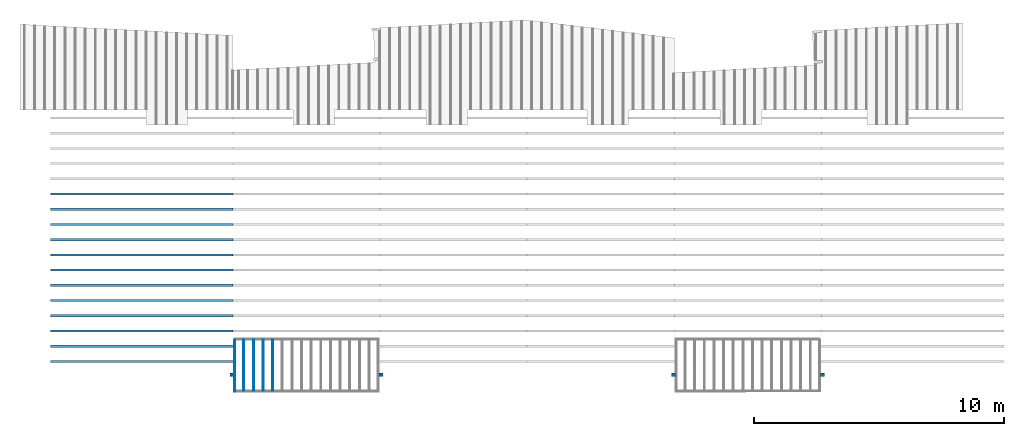
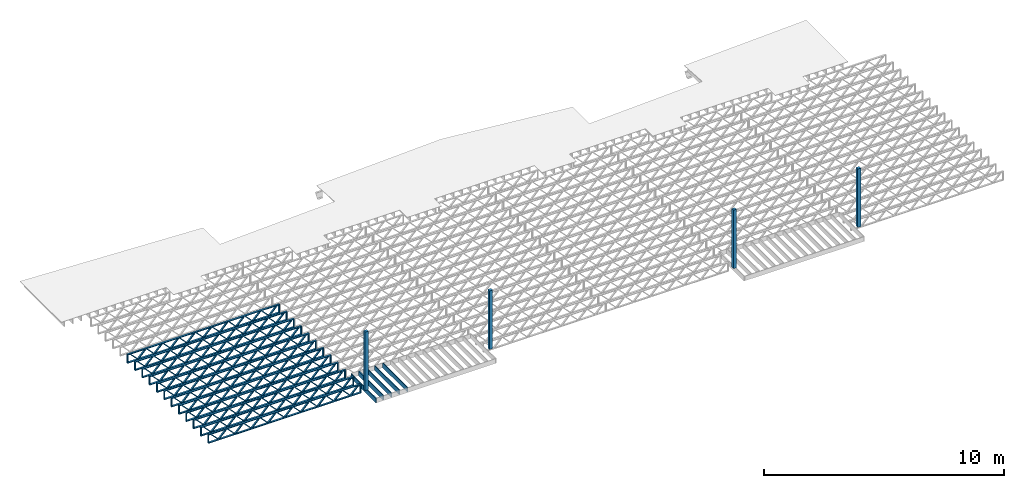
# One storey, part 1 of 13: 17 beams, 4 columns, 2 elements without a shape of their own.
"""IFC4 building model written with IfcOpenShell, lengths in feet."""

from ifc_helpers import new_model, entity, si_unit, converted_unit, derived_unit, direction, frame, frame_2d, origin, origin_2d_with_axis, place, context, subcontext, project, spatial, rectangle, extrude, source, transform, mapped, material, material_profile, profile_set, profile_usage, type_object, type_shapes, element, aggregate, save


model = new_model("IFC4")

# Units and contexts
model_context_1 = context("Model", 3, precision=0.0001, world=origin(), true_north=direction((6.12303176911189e-17, 1.0)))
model_context_2 = context("Model", 3, precision=0.0001, world=origin(), true_north=direction((6.12303176911189e-17, 1.0)))
body_context = subcontext(model_context_2, "Body", "Model", "MODEL_VIEW")
ifc_project = project(units=[converted_unit("LENGTHUNIT", "FOOT", entity("IfcRatioMeasure", 0.3048), si_unit("LENGTHUNIT", "METRE"), dimensions=[1, 0, 0, 0, 0, 0, 0]), converted_unit("AREAUNIT", "SQUARE FOOT", entity("IfcRatioMeasure", 0.09290304), si_unit("AREAUNIT", "SQUARE_METRE"), dimensions=[2, 0, 0, 0, 0, 0, 0]), converted_unit("VOLUMEUNIT", "CUBIC FOOT", entity("IfcRatioMeasure", 0.028316846592), si_unit("VOLUMEUNIT", "CUBIC_METRE"), dimensions=[3, 0, 0, 0, 0, 0, 0]), converted_unit("PLANEANGLEUNIT", "DEGREE", entity("IfcRatioMeasure", 0.0174532925199433), si_unit("PLANEANGLEUNIT", "RADIAN"), dimensions=[0, 0, 0, 0, 0, 0, 0]), si_unit("MASSUNIT", "GRAM", prefix="KILO"), derived_unit("MASSDENSITYUNIT", [(si_unit("MASSUNIT", "GRAM", prefix="KILO"), 1), (si_unit("LENGTHUNIT", "METRE"), -3)]), derived_unit("MOMENTOFINERTIAUNIT", [(si_unit("LENGTHUNIT", "METRE"), 4)]), si_unit("TIMEUNIT", "SECOND"), si_unit("FREQUENCYUNIT", "HERTZ"), si_unit("THERMODYNAMICTEMPERATUREUNIT", "DEGREE_CELSIUS"), derived_unit("THERMALTRANSMITTANCEUNIT", [(si_unit("MASSUNIT", "GRAM", prefix="KILO"), 1), (si_unit("THERMODYNAMICTEMPERATUREUNIT", "KELVIN"), -1), (si_unit("TIMEUNIT", "SECOND"), -3)]), derived_unit("VOLUMETRICFLOWRATEUNIT", [(si_unit("LENGTHUNIT", "METRE"), 3), (si_unit("TIMEUNIT", "SECOND"), -1)]), si_unit("ELECTRICCURRENTUNIT", "AMPERE"), si_unit("ELECTRICVOLTAGEUNIT", "VOLT"), si_unit("POWERUNIT", "WATT"), si_unit("FORCEUNIT", "NEWTON"), si_unit("ILLUMINANCEUNIT", "LUX"), si_unit("LUMINOUSFLUXUNIT", "LUMEN"), si_unit("LUMINOUSINTENSITYUNIT", "CANDELA"), derived_unit("USERDEFINED", [(si_unit("MASSUNIT", "GRAM", prefix="KILO"), -1), (si_unit("LENGTHUNIT", "METRE"), -2), (si_unit("TIMEUNIT", "SECOND"), 3), (si_unit("LUMINOUSFLUXUNIT", "LUMEN"), 1)]), derived_unit("LINEARVELOCITYUNIT", [(si_unit("LENGTHUNIT", "METRE"), 1), (si_unit("TIMEUNIT", "SECOND"), -1)]), si_unit("PRESSUREUNIT", "PASCAL"), derived_unit("USERDEFINED", [(si_unit("LENGTHUNIT", "METRE"), -2), (si_unit("MASSUNIT", "GRAM", prefix="KILO"), 1), (si_unit("TIMEUNIT", "SECOND"), -2)]), derived_unit("LINEARFORCEUNIT", [(si_unit("MASSUNIT", "GRAM", prefix="KILO"), 1), (si_unit("LENGTHUNIT", "METRE"), 1), (si_unit("TIMEUNIT", "SECOND"), -2), (si_unit("LENGTHUNIT", "METRE"), -1)]), derived_unit("PLANARFORCEUNIT", [(si_unit("MASSUNIT", "GRAM", prefix="KILO"), 1), (si_unit("LENGTHUNIT", "METRE"), 1), (si_unit("TIMEUNIT", "SECOND"), -2), (si_unit("LENGTHUNIT", "METRE"), -2)])], contexts=[model_context_1])

# Site, building, storey
site_placement = place(None, origin())
site = spatial("IfcSite", under=ifc_project, at=site_placement, CompositionType="ELEMENT")
building_placement = place(site_placement, origin())
building = spatial("IfcBuilding", under=site, at=building_placement, CompositionType="ELEMENT")
storey_placement = place(building_placement, frame((0.0, 0.0, 21.46875)))
storey = spatial("IfcBuildingStorey", under=building, at=storey_placement, Name="3RD FLOOR", CompositionType="ELEMENT", Elevation=21.46875)

# Columns
ifc_material_1 = material(Name="STRUCTURAL WOOD COLUMN - SIZE TBD", Category="Materials")
ifc_material_profile_1 = material_profile(ifc_material_1, rectangle(XDim=0.458333333333333, YDim=0.5, at=frame_2d((0.0, -2.77555756156289e-17), x_axis=(1.0, 0.0))), Name="(4) 2X6 - BUILT-UP COLUMN")
ifc_profile_set_1 = profile_set([ifc_material_profile_1], Name="(4) 2X6 - BUILT-UP COLUMN")
ifc_profile_usage_1 = profile_usage(ifc_profile_set_1)
column_type = type_object("IfcColumnType", Name="Timber-Column:(4) 2X6 - BUILT-UP COLUMN", PredefinedType="COLUMN", material=ifc_profile_set_1)
shared_shape_1 = source(origin(), body_context, "Body", "SweptSolid", [
    extrude(rectangle(XDim=0.458333333333333, YDim=0.5, at=frame_2d((0.0, -2.77555756156289e-17), x_axis=(1.0, 0.0))), frame((0.0, 0.0, 21.46875), z_axis=(0.0, 0.0, 1.0), x_axis=(0.0, -1.0, 0.0)), (0.0, 0.0, 1.0), 9.73958333334152),
])
type_shapes(column_type, [shared_shape_1])
column_1_placement = place(storey_placement, frame((-241.863160485529, 924.091101549317, -21.46875)))
element("IfcColumn", 1, at=column_1_placement, inside=storey, type_object=column_type, material=ifc_profile_usage_1, Name="Timber-Column:(4) 2X6 - BUILT-UP COLUMN", ObjectType="Timber-Column:(4) 2X6 - BUILT-UP COLUMN", PredefinedType="COLUMN", context=body_context, shape_type="MappedRepresentation", body=[
    mapped(shared_shape_1, transform((0.0, 0.0, 0.0), scale=1.0)),
])
ifc_profile_usage_2 = profile_usage(ifc_profile_set_1)
column_2_placement = place(storey_placement, frame((-222.279828726425, 924.091101549317, -21.46875)))
element("IfcColumn", 2, at=column_2_placement, inside=storey, type_object=column_type, material=ifc_profile_usage_2, Name="Timber-Column:(4) 2X6 - BUILT-UP COLUMN", ObjectType="Timber-Column:(4) 2X6 - BUILT-UP COLUMN", PredefinedType="COLUMN", context=body_context, shape_type="MappedRepresentation", body=[
    mapped(shared_shape_1, transform((0.0, 0.0, 0.0), scale=1.0)),
])
ifc_profile_usage_3 = profile_usage(ifc_profile_set_1)
column_3_placement = place(storey_placement, frame((-183.863160485529, 924.091101549317, -21.46875)))
element("IfcColumn", 3, at=column_3_placement, inside=storey, type_object=column_type, material=ifc_profile_usage_3, Name="Timber-Column:(4) 2X6 - BUILT-UP COLUMN", ObjectType="Timber-Column:(4) 2X6 - BUILT-UP COLUMN", PredefinedType="COLUMN", context=body_context, shape_type="MappedRepresentation", body=[
    mapped(shared_shape_1, transform((0.0, 0.0, 0.0), scale=1.0)),
])
ifc_profile_usage_4 = profile_usage(ifc_profile_set_1)
column_4_placement = place(storey_placement, frame((-164.279827152195, 924.091101549317, -21.46875)))
element("IfcColumn", 4, at=column_4_placement, inside=storey, type_object=column_type, material=ifc_profile_usage_4, Name="Timber-Column:(4) 2X6 - BUILT-UP COLUMN", ObjectType="Timber-Column:(4) 2X6 - BUILT-UP COLUMN", PredefinedType="COLUMN", context=body_context, shape_type="MappedRepresentation", body=[
    mapped(shared_shape_1, transform((0.0, 0.0, 0.0), scale=1.0)),
])

# Assembly, beams
assembly_1_placement = place(storey_placement, origin())
assembly_1 = element("IfcElementAssembly", 5, at=assembly_1_placement, inside=storey, Name="Structural Beam System:Structural Framing System", ObjectType="Structural Beam System:Structural Framing System", AssemblyPlace="NOTDEFINED", PredefinedType="BEAM_GRID")
ifc_material_2 = material(Name="WOOD TRUSS", Category="Materials")
ifc_material_profile_2 = material_profile(ifc_material_2, rectangle(XDim=1.73473973950632, YDim=0.125, at=frame_2d((-1.11022302462516e-16, 8.32667268468867e-17), x_axis=(1.0, 0.0))))
ifc_material_profile_3 = material_profile(ifc_material_2, rectangle(XDim=1.73473973950633, YDim=0.125, at=frame_2d((-1.11022302462516e-16, 8.32667268468867e-17), x_axis=(1.0, 0.0))))
ifc_material_profile_4 = material_profile(ifc_material_2, rectangle(XDim=1.73473973950632, YDim=0.125, at=frame_2d((-5.55111512312578e-17, 1.38777878078145e-16), x_axis=(1.0, 0.0))))
ifc_material_profile_5 = material_profile(ifc_material_2, rectangle(XDim=1.73473973950633, YDim=0.125, at=frame_2d((-1.11022302462516e-16, 8.32667268468867e-17), x_axis=(1.0, 0.0))))
ifc_material_profile_6 = material_profile(ifc_material_2, rectangle(XDim=1.73473973950632, YDim=0.125, at=frame_2d((-1.11022302462516e-16, 8.32667268468867e-17), x_axis=(1.0, 0.0))))
ifc_material_profile_7 = material_profile(ifc_material_2, rectangle(XDim=1.73473973950633, YDim=0.125, at=frame_2d((-2.77555756156289e-16, 3.05311331771918e-16), x_axis=(1.0, 0.0))))
ifc_material_profile_8 = material_profile(ifc_material_2, rectangle(XDim=1.73473973950632, YDim=0.124999999999999, at=frame_2d((-3.88578058618805e-16, -2.4980018054066e-16), x_axis=(1.0, 0.0))))
ifc_material_profile_9 = material_profile(ifc_material_2, rectangle(XDim=1.73473973950633, YDim=0.125, at=frame_2d((2.77555756156289e-16, -3.05311331771918e-16), x_axis=(1.0, 0.0))))
ifc_material_profile_10 = material_profile(ifc_material_2, rectangle(XDim=1.73473973950632, YDim=0.124999999999999, at=frame_2d((-1.11022302462516e-16, 8.32667268468867e-17), x_axis=(1.0, 0.0))))
ifc_material_profile_11 = material_profile(ifc_material_2, rectangle(XDim=1.73473973950633, YDim=0.125, at=origin_2d_with_axis()))
ifc_material_profile_12 = material_profile(ifc_material_2, rectangle(XDim=0.124999999999982, YDim=0.291666666666668, at=origin_2d_with_axis()))
ifc_material_profile_13 = material_profile(ifc_material_2, rectangle(XDim=0.124999999999932, YDim=0.291666666666664, at=origin_2d_with_axis()))
ifc_material_profile_14 = material_profile(ifc_material_2, rectangle(XDim=1.25000000000002, YDim=0.29166666666667, at=origin_2d_with_axis()))
ifc_material_profile_15 = material_profile(ifc_material_2, rectangle(XDim=1.25000000000004, YDim=0.291666666666667, at=origin_2d_with_axis()))
ifc_profile_set_2 = profile_set([ifc_material_profile_2, ifc_material_profile_3, ifc_material_profile_4, ifc_material_profile_5, ifc_material_profile_6, ifc_material_profile_7, ifc_material_profile_8, ifc_material_profile_9, ifc_material_profile_10, ifc_material_profile_11, ifc_material_profile_12, ifc_material_profile_13, ifc_material_profile_14, ifc_material_profile_15])
ifc_profile_usage_5 = profile_usage(ifc_profile_set_2, cardinal=8)
beam_type_1 = type_object("IfcBeamType", PredefinedType="BEAM", material=ifc_profile_set_2)
shared_shape_2 = source(origin(), body_context, "Body", "SweptSolid", [
    extrude(rectangle(XDim=1.73473973950632, YDim=0.124999999999999, at=frame_2d((5.55111512312578e-16, 7.21644966006352e-16), x_axis=(1.0, 0.0))), frame((8.42202085580899, -0.145833333333334, 0.0), z_axis=(0.0, 1.0, 0.0), x_axis=(0.693383046997606, 0.0, 0.720569184836762)), (0.0, 0.0, 1.0), 0.291666666666667),
    extrude(rectangle(XDim=1.73473973950633, YDim=0.125, at=origin_2d_with_axis()), frame((7.17173498213572, -0.145833333333334, 0.0), z_axis=(0.0, 1.0, 0.0), x_axis=(0.69338304699761, 0.0, -0.720569184836758)), (0.0, 0.0, 1.0), 0.291666666666666),
    extrude(rectangle(XDim=1.73473973950632, YDim=0.124999999999999, at=frame_2d((-1.11022302462516e-16, 8.32667268468867e-17), x_axis=(1.0, 0.0))), frame((5.82306154948498, -0.145833333333334, 0.0), z_axis=(0.0, 1.0, 0.0), x_axis=(0.693383046997606, 0.0, 0.720569184836762)), (0.0, 0.0, 1.0), 0.291666666666667),
    extrude(rectangle(XDim=1.73473973950633, YDim=0.125, at=origin_2d_with_axis()), frame((4.57277567581171, -0.145833333333334, 0.0), z_axis=(0.0, 1.0, 0.0), x_axis=(0.69338304699761, 0.0, -0.720569184836758)), (0.0, 0.0, 1.0), 0.291666666666666),
    extrude(rectangle(XDim=1.73473973950632, YDim=0.125, at=frame_2d((2.22044604925031e-16, 3.88578058618805e-16), x_axis=(1.0, 0.0))), frame((3.22410224316097, -0.145833333333334, 0.0), z_axis=(0.0, 1.0, 0.0), x_axis=(0.693383046997606, 0.0, 0.720569184836762)), (0.0, 0.0, 1.0), 0.291666666666667),
    extrude(rectangle(XDim=1.73473973950633, YDim=0.125, at=frame_2d((-1.11022302462516e-16, 8.32667268468867e-17), x_axis=(1.0, 0.0))), frame((1.9738163694877, -0.145833333333334, 0.0), z_axis=(0.0, 1.0, 0.0), x_axis=(0.69338304699761, 0.0, -0.720569184836758)), (0.0, 0.0, 1.0), 0.291666666666667),
    extrude(rectangle(XDim=1.73473973950632, YDim=0.125, at=frame_2d((-5.55111512312578e-17, 1.38777878078145e-16), x_axis=(1.0, 0.0))), frame((0.625142936836964, -0.145833333333334, 0.0), z_axis=(0.0, 1.0, 0.0), x_axis=(0.693383046997606, 0.0, 0.720569184836762)), (0.0, 0.0, 1.0), 0.291666666666667),
    extrude(rectangle(XDim=1.73473973950633, YDim=0.125, at=frame_2d((-1.11022302462516e-16, 8.32667268468867e-17), x_axis=(1.0, 0.0))), frame((-0.625142936836306, -0.145833333333334, 0.0), z_axis=(0.0, 1.0, 0.0), x_axis=(0.69338304699761, 0.0, -0.720569184836758)), (0.0, 0.0, 1.0), 0.291666666666667),
    extrude(rectangle(XDim=1.73473973950632, YDim=0.125, at=frame_2d((-1.11022302462516e-16, 8.32667268468867e-17), x_axis=(1.0, 0.0))), frame((-1.97381636948704, -0.145833333333334, 0.0), z_axis=(0.0, 1.0, 0.0), x_axis=(0.693383046997606, 0.0, 0.720569184836762)), (0.0, 0.0, 1.0), 0.291666666666667),
    extrude(rectangle(XDim=1.73473973950633, YDim=0.125, at=origin_2d_with_axis()), frame((-3.22410224316031, -0.145833333333334, 0.0), z_axis=(0.0, 1.0, 0.0), x_axis=(0.69338304699761, 0.0, -0.720569184836758)), (0.0, 0.0, 1.0), 0.291666666666667),
    extrude(rectangle(XDim=1.73473973950632, YDim=0.124999999999999, at=frame_2d((-1.11022302462516e-16, 8.32667268468867e-17), x_axis=(1.0, 0.0))), frame((-4.57277567581105, -0.145833333333334, 0.0), z_axis=(0.0, 1.0, 0.0), x_axis=(0.693383046997606, 0.0, 0.720569184836762)), (0.0, 0.0, 1.0), 0.291666666666667),
    extrude(rectangle(XDim=1.73473973950633, YDim=0.125, at=origin_2d_with_axis()), frame((-5.82306154948432, -0.145833333333334, 0.0), z_axis=(0.0, 1.0, 0.0), x_axis=(0.69338304699761, 0.0, -0.720569184836758)), (0.0, 0.0, 1.0), 0.291666666666666),
    extrude(rectangle(XDim=1.73473973950632, YDim=0.124999999999999, at=frame_2d((-1.11022302462516e-16, 8.32667268468867e-17), x_axis=(1.0, 0.0))), frame((-7.17173498213506, -0.145833333333334, 0.0), z_axis=(0.0, 1.0, 0.0), x_axis=(0.693383046997606, 0.0, 0.720569184836762)), (0.0, 0.0, 1.0), 0.291666666666667),
    extrude(rectangle(XDim=1.73473973950633, YDim=0.125, at=frame_2d((-2.77555756156289e-16, 3.05311331771918e-16), x_axis=(1.0, 0.0))), frame((-8.42202085580833, -0.145833333333334, 0.0), z_axis=(0.0, 1.0, 0.0), x_axis=(0.69338304699761, 0.0, -0.720569184836758)), (0.0, 0.0, 1.0), 0.291666666666666),
    extrude(rectangle(XDim=1.73473973950632, YDim=0.125, at=frame_2d((-7.21644966006352e-16, -5.55111512312578e-16), x_axis=(1.0, 0.0))), frame((11.020980162133, -0.145833333333334, 0.0), z_axis=(0.0, 1.0, 0.0), x_axis=(0.693383046997606, 0.0, 0.720569184836762)), (0.0, 0.0, 1.0), 0.291666666666667),
    extrude(rectangle(XDim=1.73473973950633, YDim=0.125, at=origin_2d_with_axis()), frame((9.77069428845972, -0.145833333333334, 0.0), z_axis=(0.0, 1.0, 0.0), x_axis=(0.69338304699761, 0.0, -0.720569184836758)), (0.0, 0.0, 1.0), 0.291666666666666),
    extrude(rectangle(XDim=1.73473973950632, YDim=0.125, at=frame_2d((-5.55111512312578e-17, 8.32667268468867e-17), x_axis=(1.0, 0.0))), frame((-9.77069428845906, -0.145833333333334, 0.0), z_axis=(0.0, 1.0, 0.0), x_axis=(0.693383046997606, 0.0, 0.720569184836762)), (0.0, 0.0, 1.0), 0.291666666666667),
    extrude(rectangle(XDim=1.73473973950633, YDim=0.125, at=origin_2d_with_axis()), frame((-11.0209801621323, -0.145833333333334, 0.0), z_axis=(0.0, 1.0, 0.0), x_axis=(0.69338304699761, 0.0, -0.720569184836758)), (0.0, 0.0, 1.0), 0.291666666666666),
    extrude(rectangle(XDim=0.124999999999982, YDim=0.291666666666668, at=origin_2d_with_axis()), frame((-12.0625038919626, 0.0, 0.687500000000054), z_axis=(1.0, 0.0, 0.0), x_axis=(0.0, 0.0, -1.0)), (0.0, 0.0, 1.0), 24.1250077839252),
    extrude(rectangle(XDim=0.124999999999932, YDim=0.291666666666664, at=origin_2d_with_axis()), frame((-12.0625038919624, 0.0, -0.687499999999984), z_axis=(1.0, 0.0, 0.0), x_axis=(0.0, 0.0, -1.0)), (0.0, 0.0, 1.0), 24.125007783925),
    extrude(rectangle(XDim=1.25000000000002, YDim=0.29166666666667, at=origin_2d_with_axis()), frame((11.9375038919626, 0.0, 0.0), z_axis=(1.0, 0.0, 0.0), x_axis=(0.0, 0.0, -1.0)), (0.0, 0.0, 1.0), 0.12500000000002),
    extrude(rectangle(XDim=1.25000000000004, YDim=0.291666666666667, at=origin_2d_with_axis()), frame((-12.0625038919626, 0.0, 0.0), z_axis=(1.0, 0.0, 0.0), x_axis=(0.0, 0.0, -1.0)), (0.0, 0.0, 1.0), 0.125000000000023),
])
type_shapes(beam_type_1, [shared_shape_2])
beam_1_placement = place(assembly_1_placement, frame((-253.675664405631, 927.861934882651, -0.947916666657857)))
beam_1 = element("IfcBeam", 6, at=beam_1_placement, type_object=beam_type_1, material=ifc_profile_usage_5, PredefinedType="BEAM", context=body_context, shape_type="MappedRepresentation", body=[
    mapped(shared_shape_2, transform((0.0, 0.0, 0.0), scale=1.0)),
])
ifc_profile_usage_6 = profile_usage(ifc_profile_set_2, cardinal=8)
beam_2_placement = place(assembly_1_placement, frame((-253.675664405631, 925.861934882651, -0.947916666657857)))
beam_2 = element("IfcBeam", 7, at=beam_2_placement, type_object=beam_type_1, material=ifc_profile_usage_6, PredefinedType="BEAM", context=body_context, shape_type="MappedRepresentation", body=[
    mapped(shared_shape_2, transform((0.0, 0.0, 0.0), scale=1.0)),
])

assembly_2_placement = place(storey_placement, origin())
assembly_2 = element("IfcElementAssembly", 8, at=assembly_2_placement, inside=storey, Name="Structural Beam System:Structural Framing System", ObjectType="Structural Beam System:Structural Framing System", AssemblyPlace="NOTDEFINED", PredefinedType="BEAM_GRID")
ifc_material_3 = material(Category="Materials")
ifc_material_profile_16 = material_profile(ifc_material_3, rectangle(XDim=0.770833333333333, YDim=0.124999999999994, at=frame_2d((-5.55111512312578e-17, 0.0), x_axis=(1.0, 0.0))))
ifc_profile_set_3 = profile_set([ifc_material_profile_16])
ifc_profile_usage_7 = profile_usage(ifc_profile_set_3, cardinal=8)
beam_type_2 = type_object("IfcBeamType", PredefinedType="BEAM", material=ifc_profile_set_3)
shared_shape_3 = source(origin(), body_context, "Body", "SweptSolid", [
    extrude(rectangle(XDim=0.770833333333333, YDim=0.124999999999994, at=frame_2d((-5.55111512312578e-17, 0.0), x_axis=(1.0, 0.0))), frame((-3.35416666666737, 0.0, 0.0), z_axis=(1.0, 0.0, 0.0), x_axis=(0.0, 0.0, -1.0)), (0.0, 0.0, 1.0), 6.70833333333462),
])
type_shapes(beam_type_2, [shared_shape_3])
beam_3_placement = place(assembly_2_placement, frame((-240.307864400484, 925.341101549316, -0.645833333333474), z_axis=(0.0, 0.0, 1.0), x_axis=(0.0, 1.0, 0.0)))
beam_3 = element("IfcBeam", 9, at=beam_3_placement, type_object=beam_type_2, material=ifc_profile_usage_7, PredefinedType="BEAM", context=body_context, shape_type="MappedRepresentation", body=[
    mapped(shared_shape_3, transform((0.0, 0.0, 0.0), scale=1.0)),
])
ifc_profile_usage_8 = profile_usage(ifc_profile_set_3, cardinal=8)
beam_4_placement = place(assembly_2_placement, frame((-239.040980719926, 925.341101549316, -0.645833333333474), z_axis=(0.0, 0.0, 1.0), x_axis=(0.0, 1.0, 0.0)))
beam_4 = element("IfcBeam", 10, at=beam_4_placement, type_object=beam_type_2, material=ifc_profile_usage_8, PredefinedType="BEAM", context=body_context, shape_type="MappedRepresentation", body=[
    mapped(shared_shape_3, transform((0.0, 0.0, 0.0), scale=1.0)),
])
ifc_profile_usage_9 = profile_usage(ifc_profile_set_3, cardinal=8)
beam_5_placement = place(assembly_2_placement, frame((-237.774097039367, 925.341101549316, -0.645833333333474), z_axis=(0.0, 0.0, 1.0), x_axis=(0.0, 1.0, 0.0)))
beam_5 = element("IfcBeam", 11, at=beam_5_placement, type_object=beam_type_2, material=ifc_profile_usage_9, PredefinedType="BEAM", context=body_context, shape_type="MappedRepresentation", body=[
    mapped(shared_shape_3, transform((0.0, 0.0, 0.0), scale=1.0)),
])
ifc_profile_usage_10 = profile_usage(ifc_profile_set_3, cardinal=8)
beam_6_placement = place(assembly_2_placement, frame((-236.507213358809, 925.341101549317, -0.645833333333474), z_axis=(0.0, 0.0, 1.0), x_axis=(0.0, 1.0, 0.0)))
beam_6 = element("IfcBeam", 12, at=beam_6_placement, type_object=beam_type_2, material=ifc_profile_usage_10, PredefinedType="BEAM", context=body_context, shape_type="MappedRepresentation", body=[
    mapped(shared_shape_3, transform((0.0, 0.0, 0.0), scale=1.0)),
])
aggregate(assembly_2, [beam_3, beam_4, beam_5, beam_6])

# Beam
ifc_profile_usage_11 = profile_usage(ifc_profile_set_3, cardinal=8)
beam_type_3 = type_object("IfcBeamType", PredefinedType="BEAM", material=ifc_profile_set_3)
shared_shape_4 = source(origin(), body_context, "Body", "SweptSolid", [
    extrude(rectangle(XDim=0.770833333333333, YDim=0.124999999999994, at=origin_2d_with_axis()), frame((-3.47916666666737, 0.0, 0.0), z_axis=(1.0, 0.0, 0.0), x_axis=(0.0, 0.0, -1.0)), (0.0, 0.0, 1.0), 6.83333333333471),
])
type_shapes(beam_type_3, [shared_shape_4])
beam_7_placement = place(storey_placement, frame((-241.508993604251, 925.341101549316, -0.645833333332799), z_axis=(0.0, 0.0, 1.0), x_axis=(0.0, 1.0, 0.0)))
element("IfcBeam", 13, at=beam_7_placement, inside=storey, type_object=beam_type_3, material=ifc_profile_usage_11, PredefinedType="BEAM", context=body_context, shape_type="MappedRepresentation", body=[
    mapped(shared_shape_4, transform((0.0, 0.0, 0.0), scale=1.0)),
])

ifc_profile_usage_12 = profile_usage(ifc_profile_set_2, cardinal=8)
beam_type_4 = type_object("IfcBeamType", PredefinedType="BEAM", material=ifc_profile_set_2)
shared_shape_5 = source(origin(), body_context, "Body", "SweptSolid", [
    extrude(rectangle(XDim=1.73473973950632, YDim=0.124999999999999, at=frame_2d((5.55111512312578e-16, 7.21644966006352e-16), x_axis=(1.0, 0.0))), frame((8.37514585578398, -0.145833333333334, 0.0), z_axis=(0.0, 1.0, 0.0), x_axis=(0.693383046997606, 0.0, 0.720569184836762)), (0.0, 0.0, 1.0), 0.291666666666667),
    extrude(rectangle(XDim=1.73473973950633, YDim=0.125, at=origin_2d_with_axis()), frame((7.12485998211071, -0.145833333333334, 0.0), z_axis=(0.0, 1.0, 0.0), x_axis=(0.69338304699761, 0.0, -0.720569184836758)), (0.0, 0.0, 1.0), 0.291666666666666),
    extrude(rectangle(XDim=1.73473973950632, YDim=0.124999999999999, at=frame_2d((-1.11022302462516e-16, 8.32667268468867e-17), x_axis=(1.0, 0.0))), frame((5.79181154946831, -0.145833333333334, 0.0), z_axis=(0.0, 1.0, 0.0), x_axis=(0.693383046997606, 0.0, 0.720569184836762)), (0.0, 0.0, 1.0), 0.291666666666667),
    extrude(rectangle(XDim=1.73473973950633, YDim=0.125, at=origin_2d_with_axis()), frame((4.54152567579504, -0.145833333333334, 0.0), z_axis=(0.0, 1.0, 0.0), x_axis=(0.69338304699761, 0.0, -0.720569184836758)), (0.0, 0.0, 1.0), 0.291666666666666),
    extrude(rectangle(XDim=1.73473973950632, YDim=0.125, at=frame_2d((2.22044604925031e-16, 3.88578058618805e-16), x_axis=(1.0, 0.0))), frame((3.20847724315264, -0.145833333333334, 0.0), z_axis=(0.0, 1.0, 0.0), x_axis=(0.693383046997606, 0.0, 0.720569184836762)), (0.0, 0.0, 1.0), 0.291666666666667),
    extrude(rectangle(XDim=1.73473973950633, YDim=0.125, at=frame_2d((-1.11022302462516e-16, 8.32667268468867e-17), x_axis=(1.0, 0.0))), frame((1.95819136947937, -0.145833333333334, 0.0), z_axis=(0.0, 1.0, 0.0), x_axis=(0.69338304699761, 0.0, -0.720569184836758)), (0.0, 0.0, 1.0), 0.291666666666667),
    extrude(rectangle(XDim=1.73473973950632, YDim=0.125, at=frame_2d((-5.55111512312578e-17, 1.38777878078145e-16), x_axis=(1.0, 0.0))), frame((0.625142936836964, -0.145833333333334, 0.0), z_axis=(0.0, 1.0, 0.0), x_axis=(0.693383046997606, 0.0, 0.720569184836762)), (0.0, 0.0, 1.0), 0.291666666666667),
    extrude(rectangle(XDim=1.73473973950633, YDim=0.125, at=frame_2d((-1.11022302462516e-16, 8.32667268468867e-17), x_axis=(1.0, 0.0))), frame((-0.625142936836306, -0.145833333333334, 0.0), z_axis=(0.0, 1.0, 0.0), x_axis=(0.69338304699761, 0.0, -0.720569184836758)), (0.0, 0.0, 1.0), 0.291666666666667),
    extrude(rectangle(XDim=1.73473973950632, YDim=0.125, at=frame_2d((-1.11022302462516e-16, 8.32667268468867e-17), x_axis=(1.0, 0.0))), frame((-1.95819136947871, -0.145833333333334, 0.0), z_axis=(0.0, 1.0, 0.0), x_axis=(0.693383046997606, 0.0, 0.720569184836762)), (0.0, 0.0, 1.0), 0.291666666666667),
    extrude(rectangle(XDim=1.73473973950633, YDim=0.125, at=origin_2d_with_axis()), frame((-3.20847724315198, -0.145833333333334, 0.0), z_axis=(0.0, 1.0, 0.0), x_axis=(0.69338304699761, 0.0, -0.720569184836758)), (0.0, 0.0, 1.0), 0.291666666666667),
    extrude(rectangle(XDim=1.73473973950632, YDim=0.124999999999999, at=frame_2d((-1.11022302462516e-16, 8.32667268468867e-17), x_axis=(1.0, 0.0))), frame((-4.54152567579438, -0.145833333333334, 0.0), z_axis=(0.0, 1.0, 0.0), x_axis=(0.693383046997606, 0.0, 0.720569184836762)), (0.0, 0.0, 1.0), 0.291666666666667),
    extrude(rectangle(XDim=1.73473973950633, YDim=0.125, at=origin_2d_with_axis()), frame((-5.79181154946765, -0.145833333333334, 0.0), z_axis=(0.0, 1.0, 0.0), x_axis=(0.69338304699761, 0.0, -0.720569184836758)), (0.0, 0.0, 1.0), 0.291666666666666),
    extrude(rectangle(XDim=1.73473973950632, YDim=0.124999999999999, at=frame_2d((-1.11022302462516e-16, 8.32667268468867e-17), x_axis=(1.0, 0.0))), frame((-7.12485998211005, -0.145833333333334, 0.0), z_axis=(0.0, 1.0, 0.0), x_axis=(0.693383046997606, 0.0, 0.720569184836762)), (0.0, 0.0, 1.0), 0.291666666666667),
    extrude(rectangle(XDim=1.73473973950633, YDim=0.125, at=frame_2d((-2.77555756156289e-16, 3.05311331771918e-16), x_axis=(1.0, 0.0))), frame((-8.37514585578332, -0.145833333333334, 0.0), z_axis=(0.0, 1.0, 0.0), x_axis=(0.69338304699761, 0.0, -0.720569184836758)), (0.0, 0.0, 1.0), 0.291666666666666),
    extrude(rectangle(XDim=1.73473973950632, YDim=0.125, at=frame_2d((-7.21644966006352e-16, -5.55111512312578e-16), x_axis=(1.0, 0.0))), frame((10.9584801620997, -0.145833333333334, 0.0), z_axis=(0.0, 1.0, 0.0), x_axis=(0.693383046997606, 0.0, 0.720569184836762)), (0.0, 0.0, 1.0), 0.291666666666667),
    extrude(rectangle(XDim=1.73473973950633, YDim=0.125, at=origin_2d_with_axis()), frame((9.70819428842638, -0.145833333333334, 0.0), z_axis=(0.0, 1.0, 0.0), x_axis=(0.69338304699761, 0.0, -0.720569184836758)), (0.0, 0.0, 1.0), 0.291666666666666),
    extrude(rectangle(XDim=1.73473973950632, YDim=0.125, at=frame_2d((-5.55111512312578e-17, 8.32667268468867e-17), x_axis=(1.0, 0.0))), frame((-9.70819428842572, -0.145833333333334, 0.0), z_axis=(0.0, 1.0, 0.0), x_axis=(0.693383046997606, 0.0, 0.720569184836762)), (0.0, 0.0, 1.0), 0.291666666666667),
    extrude(rectangle(XDim=1.73473973950633, YDim=0.125, at=origin_2d_with_axis()), frame((-10.958480162099, -0.145833333333334, 0.0), z_axis=(0.0, 1.0, 0.0), x_axis=(0.69338304699761, 0.0, -0.720569184836758)), (0.0, 0.0, 1.0), 0.291666666666666),
    extrude(rectangle(XDim=0.124999999999982, YDim=0.291666666666668, at=origin_2d_with_axis()), frame((-12.0000038919293, 0.0, 0.687500000000054), z_axis=(1.0, 0.0, 0.0), x_axis=(0.0, 0.0, -1.0)), (0.0, 0.0, 1.0), 24.0000077838585),
    extrude(rectangle(XDim=0.124999999999932, YDim=0.291666666666664, at=origin_2d_with_axis()), frame((-12.0000038919291, 0.0, -0.687499999999984), z_axis=(1.0, 0.0, 0.0), x_axis=(0.0, 0.0, -1.0)), (0.0, 0.0, 1.0), 24.0000077838583),
    extrude(rectangle(XDim=1.25000000000002, YDim=0.29166666666667, at=origin_2d_with_axis()), frame((11.8750038919292, 0.0, 0.0), z_axis=(1.0, 0.0, 0.0), x_axis=(0.0, 0.0, -1.0)), (0.0, 0.0, 1.0), 0.12500000000002),
    extrude(rectangle(XDim=1.25000000000004, YDim=0.291666666666667, at=origin_2d_with_axis()), frame((-12.0000038919293, 0.0, 0.0), z_axis=(1.0, 0.0, 0.0), x_axis=(0.0, 0.0, -1.0)), (0.0, 0.0, 1.0), 0.125000000000023),
])
type_shapes(beam_type_4, [shared_shape_5])
beam_8_placement = place(assembly_1_placement, frame((-253.738164405664, 929.861934882651, -0.947916666657857)))
beam_8 = element("IfcBeam", 14, at=beam_8_placement, type_object=beam_type_4, material=ifc_profile_usage_12, PredefinedType="BEAM", context=body_context, shape_type="MappedRepresentation", body=[
    mapped(shared_shape_5, transform((0.0, 0.0, 0.0), scale=1.0)),
])

ifc_profile_usage_13 = profile_usage(ifc_profile_set_2, cardinal=8)
beam_9_placement = place(assembly_1_placement, frame((-253.738164405664, 931.861934882651, -0.947916666657857)))
beam_9 = element("IfcBeam", 15, at=beam_9_placement, type_object=beam_type_4, material=ifc_profile_usage_13, PredefinedType="BEAM", context=body_context, shape_type="MappedRepresentation", body=[
    mapped(shared_shape_5, transform((0.0, 0.0, 0.0), scale=1.0)),
])

ifc_profile_usage_14 = profile_usage(ifc_profile_set_2, cardinal=8)
beam_10_placement = place(assembly_1_placement, frame((-253.738164405664, 933.861934882651, -0.947916666657857)))
beam_10 = element("IfcBeam", 16, at=beam_10_placement, type_object=beam_type_4, material=ifc_profile_usage_14, PredefinedType="BEAM", context=body_context, shape_type="MappedRepresentation", body=[
    mapped(shared_shape_5, transform((0.0, 0.0, 0.0), scale=1.0)),
])

ifc_profile_usage_15 = profile_usage(ifc_profile_set_2, cardinal=8)
beam_11_placement = place(assembly_1_placement, frame((-253.738164405664, 935.861934882651, -0.947916666657857)))
beam_11 = element("IfcBeam", 17, at=beam_11_placement, type_object=beam_type_4, material=ifc_profile_usage_15, PredefinedType="BEAM", context=body_context, shape_type="MappedRepresentation", body=[
    mapped(shared_shape_5, transform((0.0, 0.0, 0.0), scale=1.0)),
])

ifc_profile_usage_16 = profile_usage(ifc_profile_set_2, cardinal=8)
beam_12_placement = place(assembly_1_placement, frame((-253.738164405664, 937.861934882651, -0.947916666657857)))
beam_12 = element("IfcBeam", 18, at=beam_12_placement, type_object=beam_type_4, material=ifc_profile_usage_16, PredefinedType="BEAM", context=body_context, shape_type="MappedRepresentation", body=[
    mapped(shared_shape_5, transform((0.0, 0.0, 0.0), scale=1.0)),
])

ifc_profile_usage_17 = profile_usage(ifc_profile_set_2, cardinal=8)
beam_13_placement = place(assembly_1_placement, frame((-253.738164405664, 939.861934882651, -0.947916666657857)))
beam_13 = element("IfcBeam", 19, at=beam_13_placement, type_object=beam_type_4, material=ifc_profile_usage_17, PredefinedType="BEAM", context=body_context, shape_type="MappedRepresentation", body=[
    mapped(shared_shape_5, transform((0.0, 0.0, 0.0), scale=1.0)),
])

ifc_profile_usage_18 = profile_usage(ifc_profile_set_2, cardinal=8)
beam_14_placement = place(assembly_1_placement, frame((-253.738164405664, 941.861934882651, -0.947916666657857)))
beam_14 = element("IfcBeam", 20, at=beam_14_placement, type_object=beam_type_4, material=ifc_profile_usage_18, PredefinedType="BEAM", context=body_context, shape_type="MappedRepresentation", body=[
    mapped(shared_shape_5, transform((0.0, 0.0, 0.0), scale=1.0)),
])

ifc_profile_usage_19 = profile_usage(ifc_profile_set_2, cardinal=8)
beam_15_placement = place(assembly_1_placement, frame((-253.738164405664, 943.861934882651, -0.947916666657857)))
beam_15 = element("IfcBeam", 21, at=beam_15_placement, type_object=beam_type_4, material=ifc_profile_usage_19, PredefinedType="BEAM", context=body_context, shape_type="MappedRepresentation", body=[
    mapped(shared_shape_5, transform((0.0, 0.0, 0.0), scale=1.0)),
])

ifc_profile_usage_20 = profile_usage(ifc_profile_set_2, cardinal=8)
beam_16_placement = place(assembly_1_placement, frame((-253.738164405664, 945.861934882651, -0.947916666657857)))
beam_16 = element("IfcBeam", 22, at=beam_16_placement, type_object=beam_type_4, material=ifc_profile_usage_20, PredefinedType="BEAM", context=body_context, shape_type="MappedRepresentation", body=[
    mapped(shared_shape_5, transform((0.0, 0.0, 0.0), scale=1.0)),
])

ifc_profile_usage_21 = profile_usage(ifc_profile_set_2, cardinal=8)
beam_17_placement = place(assembly_1_placement, frame((-253.738164405664, 947.861934882651, -0.947916666657857)))
beam_17 = element("IfcBeam", 23, at=beam_17_placement, type_object=beam_type_4, material=ifc_profile_usage_21, PredefinedType="BEAM", context=body_context, shape_type="MappedRepresentation", body=[
    mapped(shared_shape_5, transform((0.0, 0.0, 0.0), scale=1.0)),
])

aggregate(assembly_1, [beam_1, beam_2, beam_8, beam_9, beam_10, beam_11, beam_12, beam_13, beam_14, beam_15, beam_16, beam_17])

save(model, "model.ifc")
